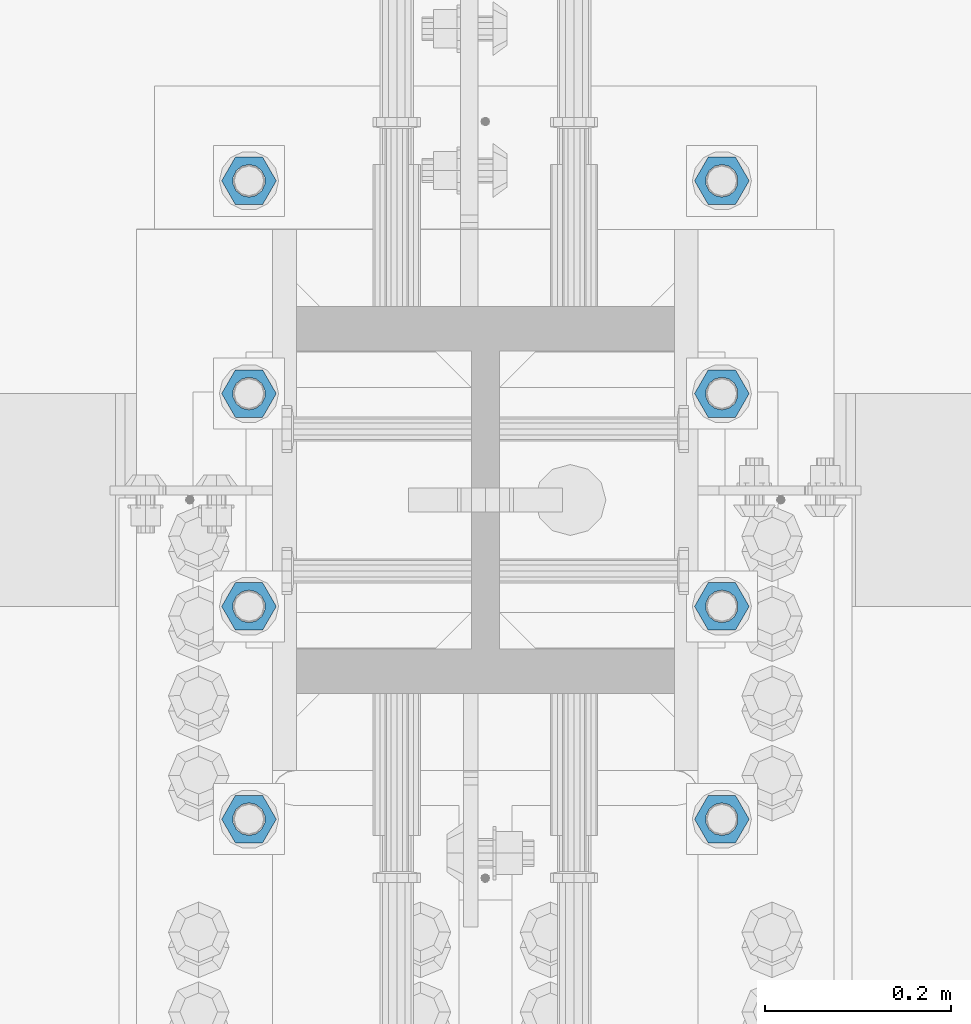
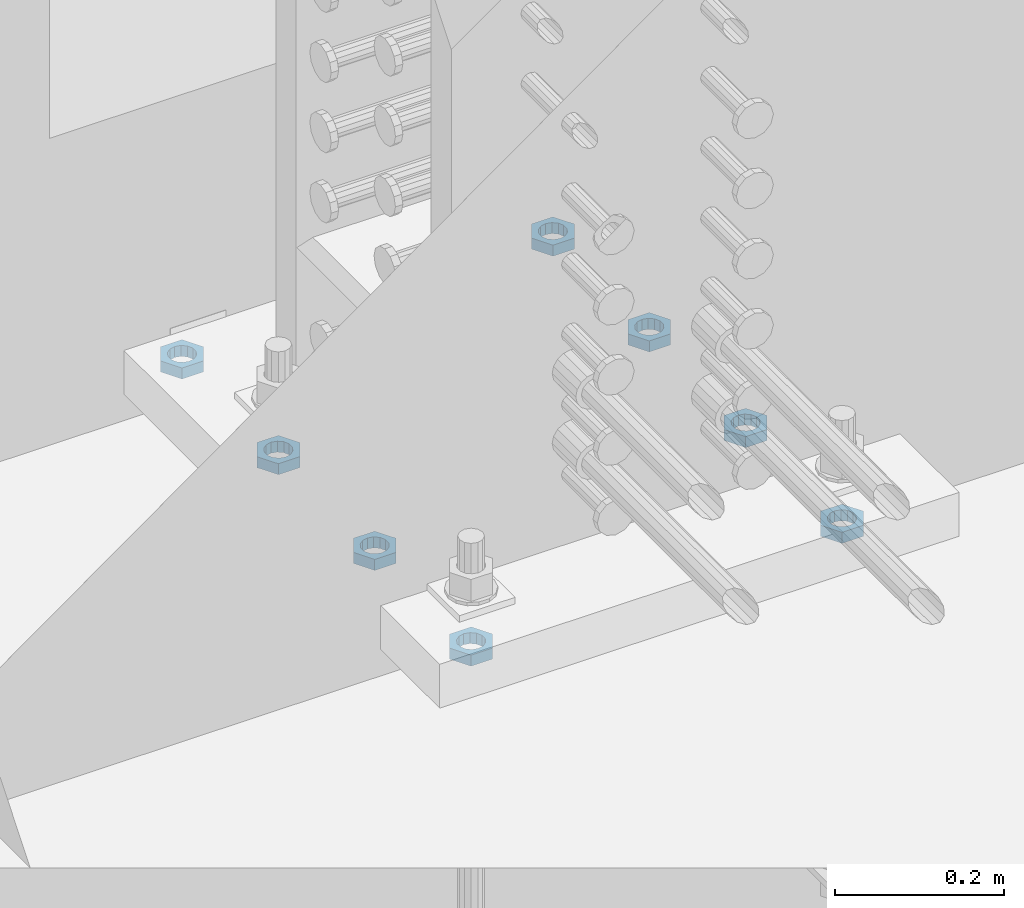
# One storey, part 1402 of 1763: 8 beams, 1 element without a shape of its own.
"""IFC2X3 building model written with IfcOpenShell, lengths in millimetres."""

import ifcopenshell
import ifcopenshell.guid

model = None  # the IFC model being written
_history = None  # IfcOwnerHistory: only IFC2X3 demands one
_inside = {}  # id of a spatial element -> (the spatial element, [elements in it])
_under = {}  # id of a project, library or spatial element -> (it, [spatial elements below it])
_declared = {}  # id of a project -> (the project, [libraries it declares])
_typed = {}  # id of a type object -> (the type object, [elements of that type])
_made_of = {}  # id of a material, layer set ... -> (it, [elements and type objects made of it])


def new_model(schema):
    """Start an empty IFC model of exactly this schema.

    Asked for "IFC4X3", IfcOpenShell would pick the latest addendum, in which some entities
    have other attributes; the version numbers below select the first issue.
    IFC2X3 requires an IfcOwnerHistory on every rooted entity: one is made here for all.
    """
    global model, _history
    if schema == "IFC4X3":
        model = ifcopenshell.file(schema_version=(4, 3, 0, 0))
    else:
        model = ifcopenshell.file(schema=schema)
    _inside.clear()
    _under.clear()
    _declared.clear()
    _typed.clear()
    _made_of.clear()
    _history = None
    if model.schema == "IFC2X3":
        org = make("IfcOrganization", Name="unknown")
        user = make(
            "IfcPersonAndOrganization",
            ThePerson=make("IfcPerson", FamilyName="unknown"),
            TheOrganization=org,
        )
        app = make(
            "IfcApplication",
            ApplicationDeveloper=org,
            Version="unknown",
            ApplicationFullName="unknown",
            ApplicationIdentifier="unknown",
        )
        _history = make(
            "IfcOwnerHistory",
            OwningUser=user,
            OwningApplication=app,
            ChangeAction="ADDED",
            CreationDate=0,
        )
    return model


def make(cls, **values):
    """One entity of the class cls with the attributes given. An attribute that is None is left unset."""
    return model.create_entity(
        cls, **{name: value for name, value in values.items() if value is not None}
    )


def rooted(cls, **values):
    """An entity with a GlobalId (a new one), such as an element, a storey or a relation."""
    return make(cls, GlobalId=ifcopenshell.guid.new(), OwnerHistory=_history, **values)


def si_unit(unit_type, name, prefix=None):
    """IfcSIUnit, for example si_unit("LENGTHUNIT", "METRE", prefix="MILLI")."""
    return make("IfcSIUnit", UnitType=unit_type, Prefix=prefix, Name=name)


def assignment(units):
    """IfcUnitAssignment: the units of a project."""
    return None if units is None else make("IfcUnitAssignment", Units=units)


def point(xyz):
    """IfcCartesianPoint."""
    return None if xyz is None else make("IfcCartesianPoint", Coordinates=xyz)


def direction(xyz):
    """IfcDirection."""
    return None if xyz is None else make("IfcDirection", DirectionRatios=xyz)


def frame(location, z_axis=None, x_axis=None):
    """IfcAxis2Placement3D, a coordinate frame: its origin and axes. An axis left out is left unset."""
    return make(
        "IfcAxis2Placement3D",
        Location=point(location),
        Axis=direction(z_axis),
        RefDirection=direction(x_axis),
    )


def origin_with_axes():
    """The frame at (0, 0, 0) with the z axis (0, 0, 1) and the x axis (1, 0, 0) written out."""
    return frame((0.0, 0.0, 0.0), z_axis=(0.0, 0.0, 1.0), x_axis=(1.0, 0.0, 0.0))


def place(relative_to, where):
    """IfcLocalPlacement: puts the frame where relative to a parent placement (None: the world)."""
    return make(
        "IfcLocalPlacement", PlacementRelTo=relative_to, RelativePlacement=where
    )


def context(
    kind, dimensions, precision=None, world=None, true_north=None, identifier=None
):
    """IfcGeometricRepresentationContext, for example the 3D "Model" context."""
    return make(
        "IfcGeometricRepresentationContext",
        ContextIdentifier=identifier,
        ContextType=kind,
        CoordinateSpaceDimension=dimensions,
        Precision=precision,
        WorldCoordinateSystem=world,
        TrueNorth=true_north,
    )


def subcontext(parent, identifier, kind, view, scale=None):
    """IfcGeometricRepresentationSubContext, for example "Body" below "Model"."""
    return make(
        "IfcGeometricRepresentationSubContext",
        ContextIdentifier=identifier,
        ContextType=kind,
        ParentContext=parent,
        TargetScale=scale,
        TargetView=view,
    )


def project(units=None, contexts=None):
    """IfcProject with its units and contexts."""
    return rooted(
        "IfcProject",
        Name="project",
        RepresentationContexts=contexts,
        UnitsInContext=assignment(units),
    )


def spatial(cls, under=None, at=None, **own):
    """A site, building, storey or space (cls), placed at a placement, below another one or the project."""
    s = rooted(cls, ObjectPlacement=at, **own)
    if under is not None:
        _under.setdefault(under.id(), (under, []))[1].append(s)
    return s


def faces_of(points, faces, orient=None, outer=None):
    """IfcFace entities. A face is a list of loops; a loop is a list of indices into points, from 0.

    orient and outer hold one flag for each loop. By default every Orientation is true, the
    first loop of a face is its IfcFaceOuterBound and the others are IfcFaceBound.
    """
    made = []
    for i, loops in enumerate(faces):
        bounds = []
        for j, loop in enumerate(loops):
            is_outer = j == 0 if outer is None else outer[i][j]
            bounds.append(
                make(
                    "IfcFaceOuterBound" if is_outer else "IfcFaceBound",
                    Bound=make("IfcPolyLoop", Polygon=[points[k] for k in loop]),
                    Orientation=True if orient is None else orient[i][j],
                )
            )
        made.append(make("IfcFace", Bounds=bounds))
    return made


def faceted_brep(points, faces, orient=None, outer=None, voids=None):
    """IfcFacetedBrep: a solid bounded by flat faces; with voids (closed shells), ...WithVoids."""
    shared = [point(p) for p in points]
    hull = make("IfcClosedShell", CfsFaces=faces_of(shared, faces, orient, outer))
    if voids is None:
        return make("IfcFacetedBrep", Outer=hull)
    return make(
        "IfcFacetedBrepWithVoids",
        Outer=hull,
        Voids=[
            make(cls, CfsFaces=faces_of(shared, fs, o, b)) for cls, fs, o, b in voids
        ],
    )


def shape(context_of_items, identifier, shape_type, items):
    """IfcShapeRepresentation: the items that make up one representation, for example the "Body"."""
    return make(
        "IfcShapeRepresentation",
        ContextOfItems=context_of_items,
        RepresentationIdentifier=identifier,
        RepresentationType=shape_type,
        Items=items,
    )


def material(Name=None, Category=None):
    """IfcMaterial."""
    return make("IfcMaterial", Name=Name, Category=Category)


def made_of(thing, what):
    """Note that an element or type object is made of a material, layer set ...; save() writes the relation."""
    if what is not None:
        _made_of.setdefault(what.id(), (what, []))[1].append(thing)
    return thing


def type_object(cls, material=None, **own):
    """A type object (cls), such as IfcWallType, which elements share."""
    return made_of(rooted(cls, **own), material)


def element(
    cls,
    number,
    at=None,
    inside=None,
    cuts=None,
    type_object=None,
    material=None,
    context=None,
    identifier="Body",
    shape_type=None,
    held_by="IfcProductDefinitionShape",
    body=None,
    shapes=None,
    **own,
):
    """One element of the class cls, such as IfcWall. Its Tag is "e" and its number.

    at: its placement. inside: the storey or other place that contains it. cuts: it is an
    opening in that element (IfcRelVoidsElement). A single representation is given by context,
    identifier, shape_type and body (its items); several are given by shapes. held_by: the class
    of the entity that holds the representations. save() writes the other relations.
    """
    e = rooted(cls, Tag="e%d" % number, ObjectPlacement=at, **own)
    if body is not None:
        shapes = [shape(context, identifier, shape_type, body)]
    if shapes is not None:
        e.Representation = make(held_by, Representations=shapes)
    if inside is not None:
        _inside.setdefault(inside.id(), (inside, []))[1].append(e)
    if cuts is not None:
        rooted(
            "IfcRelVoidsElement", RelatingBuildingElement=cuts, RelatedOpeningElement=e
        )
    if type_object is not None:
        _typed.setdefault(type_object.id(), (type_object, []))[1].append(e)
    return made_of(e, material)


def aggregate(whole, parts):
    """IfcRelAggregates: a whole, such as a stair, and the parts it consists of."""
    return rooted("IfcRelAggregates", RelatingObject=whole, RelatedObjects=parts)


def save(model, path):
    """Write the relations noted so far, then the file.

    IfcRelAggregates (storeys below a building ...), IfcRelContainedInSpatialStructure (elements
    in a storey), IfcRelDefinesByType, IfcRelAssociatesMaterial and IfcRelDeclares: one each for
    every whole, place, type object, material and project.
    """
    for whole, parts in _under.values():
        aggregate(whole, parts)
    for where, things in _inside.values():
        rooted(
            "IfcRelContainedInSpatialStructure",
            RelatedElements=things,
            RelatingStructure=where,
        )
    for kind, things in _typed.values():
        rooted("IfcRelDefinesByType", RelatedObjects=things, RelatingType=kind)
    for what, things in _made_of.values():
        rooted("IfcRelAssociatesMaterial", RelatedObjects=things, RelatingMaterial=what)
    for by, libraries in _declared.values():
        rooted("IfcRelDeclares", RelatingContext=by, RelatedDefinitions=libraries)
    model.write(path)


model = new_model("IFC2X3")

# Units and contexts
model_context = context("Model", 3, precision=1e-05, world=origin_with_axes())
body_context = subcontext(model_context, "Body", "Model", "MODEL_VIEW")
ifc_project = project(units=[si_unit("LENGTHUNIT", "METRE", prefix="MILLI"), si_unit("AREAUNIT", "SQUARE_METRE"), si_unit("VOLUMEUNIT", "CUBIC_METRE"), si_unit("MASSUNIT", "GRAM", prefix="KILO"), si_unit("TIMEUNIT", "SECOND"), si_unit("PLANEANGLEUNIT", "RADIAN"), si_unit("SOLIDANGLEUNIT", "STERADIAN"), si_unit("THERMODYNAMICTEMPERATUREUNIT", "DEGREE_CELSIUS"), si_unit("LUMINOUSINTENSITYUNIT", "LUMEN")], contexts=[model_context])

# Site, building, storey
site_placement = place(None, origin_with_axes())
site = spatial("IfcSite", under=ifc_project, at=site_placement, CompositionType="ELEMENT")
building_placement = place(site_placement, origin_with_axes())
building = spatial("IfcBuilding", under=site, at=building_placement, Name="Undefined", CompositionType="ELEMENT")
storey_placement = place(building_placement, origin_with_axes())
storey = spatial("IfcBuildingStorey", under=building, at=storey_placement, Name="Undefined", CompositionType="ELEMENT", Elevation=0.0)

# Assembly, beams
assembly_placement = place(storey_placement, origin_with_axes())
assembly = element("IfcElementAssembly", 1, at=assembly_placement, inside=storey, Name="TEMPLATE", AssemblyPlace="NOTDEFINED", PredefinedType="RIGID_FRAME")
ifc_material = material(Name="STEEL/A563")
beam_type = type_object("IfcBeamType", Name="1-1/4_DIA. HALF_NUT", PredefinedType="NOTDEFINED")
beam_1_placement = place(assembly_placement, frame((-23773.8372736984, 14033.4999999999, 3848.1), z_axis=(0.0, 1.0, 0.0), x_axis=(0.0, 0.0, -1.0)))
beam_1 = element("IfcBeam", 2, at=beam_1_placement, type_object=beam_type, material=ifc_material, Name="NUT", ObjectType="1-1/4_DIA. HALF_NUT", context=body_context, shape_type="Brep", body=[
    faceted_brep([(0.0, -29.3700008392334, 0.0), (0.0, -14.6800003051758, -25.4300003051758), (15.875, -14.6800003051758, -25.4300003051758), (15.875, -29.3700008392334, 0.0), (0.0, 14.6800003051758, -25.4300003051758), (15.875, 14.6800003051758, -25.4300003051758), (0.0, 29.3700008392334, 0.0), (15.875, 29.3700008392334, 0.0), (0.0, 14.6800003051758, 25.4300003051758), (15.875, 14.6800003051758, 25.4300003051758), (0.0, -14.6800003051758, 25.4300003051758), (15.875, -14.6800003051758, 25.4300003051758), (0.0, 0.0, 17.4599990844727), (0.0, 7.57560968776022, 15.730915608714), (15.875, 7.57560968776022, 15.730915608714), (15.875, 0.0, 17.4599990844727), (0.0, 13.6507769681037, 10.8861313696252), (15.875, 13.6507769681037, 10.8861313696252), (0.0, 17.0222404541215, 3.88521530314756), (15.875, 17.0222404541215, 3.88521530314756), (0.0, 17.0222404541215, -3.88521530314756), (15.875, 17.0222404541215, -3.88521530314756), (0.0, 13.6507769681037, -10.8861313696252), (15.875, 13.6507769681037, -10.8861313696252), (0.0, 7.57560968776022, -15.730915608714), (15.875, 7.57560968776022, -15.730915608714), (0.0, 0.0, -17.4599990844727), (15.875, 0.0, -17.4599990844727), (0.0, -7.57560968776022, -15.730915608714), (15.875, -7.57560968776022, -15.730915608714), (0.0, -13.6507769681037, -10.8861313696252), (15.875, -13.6507769681037, -10.8861313696252), (0.0, -17.0222404541215, -3.88521530314756), (15.875, -17.0222404541215, -3.88521530314756), (0.0, -17.0222404541215, 3.88521530314756), (15.875, -17.0222404541215, 3.88521530314756), (0.0, -13.6507769681037, 10.8861313696252), (15.875, -13.6507769681037, 10.8861313696252), (0.0, -7.57560968776022, 15.730915608714), (15.875, -7.57560968776022, 15.730915608714)], [[[0, 1, 2, 3]], [[1, 4, 5, 2]], [[4, 6, 7, 5]], [[6, 8, 9, 7]], [[8, 10, 11, 9]], [[10, 0, 3, 11]], [[12, 13, 14, 15]], [[13, 16, 17, 14]], [[16, 18, 19, 17]], [[18, 20, 21, 19]], [[20, 22, 23, 21]], [[22, 24, 25, 23]], [[24, 26, 27, 25]], [[26, 28, 29, 27]], [[28, 30, 31, 29]], [[30, 32, 33, 31]], [[32, 34, 35, 33]], [[34, 36, 37, 35]], [[36, 38, 39, 37]], [[38, 12, 15, 39]], [[5, 7, 9, 11, 3, 2], [17, 19, 21, 23, 25, 27, 29, 31, 33, 35, 37, 39, 15, 14]], [[10, 8, 6, 4, 1, 0], [38, 36, 34, 32, 30, 28, 26, 24, 22, 20, 18, 16, 13, 12]]]),
])
beam_2_placement = place(assembly_placement, frame((-24281.8372736984, 14033.4999999999, 3848.1), z_axis=(0.0, -1.0, 0.0), x_axis=(0.0, 0.0, -1.0)))
beam_2 = element("IfcBeam", 3, at=beam_2_placement, type_object=beam_type, material=ifc_material, Name="NUT", ObjectType="1-1/4_DIA. HALF_NUT", context=body_context, shape_type="Brep", body=[
    faceted_brep([(0.0, -29.3700008392334, 0.0), (0.0, -14.6800003051758, -25.4300003051758), (15.875, -14.6800003051758, -25.4300003051758), (15.875, -29.3700008392334, 0.0), (0.0, 14.6800003051758, -25.4300003051758), (15.875, 14.6800003051758, -25.4300003051758), (0.0, 29.3700008392334, 0.0), (15.875, 29.3700008392334, 0.0), (0.0, 14.6800003051758, 25.4300003051758), (15.875, 14.6800003051758, 25.4300003051758), (0.0, -14.6800003051758, 25.4300003051758), (15.875, -14.6800003051758, 25.4300003051758), (0.0, 0.0, 17.4599990844727), (0.0, 7.57560968776022, 15.730915608714), (15.875, 7.57560968776022, 15.730915608714), (15.875, 0.0, 17.4599990844727), (0.0, 13.6507769681037, 10.8861313696252), (15.875, 13.6507769681037, 10.8861313696252), (0.0, 17.0222404541215, 3.88521530314756), (15.875, 17.0222404541215, 3.88521530314756), (0.0, 17.0222404541215, -3.88521530314756), (15.875, 17.0222404541215, -3.88521530314756), (0.0, 13.6507769681037, -10.8861313696252), (15.875, 13.6507769681037, -10.8861313696252), (0.0, 7.57560968776022, -15.730915608714), (15.875, 7.57560968776022, -15.730915608714), (0.0, 0.0, -17.4599990844727), (15.875, 0.0, -17.4599990844727), (0.0, -7.57560968776022, -15.730915608714), (15.875, -7.57560968776022, -15.730915608714), (0.0, -13.6507769681037, -10.8861313696252), (15.875, -13.6507769681037, -10.8861313696252), (0.0, -17.0222404541215, -3.88521530314756), (15.875, -17.0222404541215, -3.88521530314756), (0.0, -17.0222404541215, 3.88521530314756), (15.875, -17.0222404541215, 3.88521530314756), (0.0, -13.6507769681037, 10.8861313696252), (15.875, -13.6507769681037, 10.8861313696252), (0.0, -7.57560968776022, 15.730915608714), (15.875, -7.57560968776022, 15.730915608714)], [[[0, 1, 2, 3]], [[1, 4, 5, 2]], [[4, 6, 7, 5]], [[6, 8, 9, 7]], [[8, 10, 11, 9]], [[10, 0, 3, 11]], [[12, 13, 14, 15]], [[13, 16, 17, 14]], [[16, 18, 19, 17]], [[18, 20, 21, 19]], [[20, 22, 23, 21]], [[22, 24, 25, 23]], [[24, 26, 27, 25]], [[26, 28, 29, 27]], [[28, 30, 31, 29]], [[30, 32, 33, 31]], [[32, 34, 35, 33]], [[34, 36, 37, 35]], [[36, 38, 39, 37]], [[38, 12, 15, 39]], [[5, 7, 9, 11, 3, 2], [17, 19, 21, 23, 25, 27, 29, 31, 33, 35, 37, 39, 15, 14]], [[10, 8, 6, 4, 1, 0], [38, 36, 34, 32, 30, 28, 26, 24, 22, 20, 18, 16, 13, 12]]]),
])
beam_3_placement = place(assembly_placement, frame((-23773.8372736984, 13804.8999999999, 3848.1), z_axis=(0.0, 1.0, 0.0), x_axis=(0.0, 0.0, -1.0)))
beam_3 = element("IfcBeam", 4, at=beam_3_placement, type_object=beam_type, material=ifc_material, Name="NUT", ObjectType="1-1/4_DIA. HALF_NUT", context=body_context, shape_type="Brep", body=[
    faceted_brep([(0.0, -29.3700008392334, 0.0), (0.0, -14.6800003051758, -25.4300003051758), (15.875, -14.6800003051758, -25.4300003051758), (15.875, -29.3700008392334, 0.0), (0.0, 14.6800003051758, -25.4300003051758), (15.875, 14.6800003051758, -25.4300003051758), (0.0, 29.3700008392334, 0.0), (15.875, 29.3700008392334, 0.0), (0.0, 14.6800003051758, 25.4300003051758), (15.875, 14.6800003051758, 25.4300003051758), (0.0, -14.6800003051758, 25.4300003051758), (15.875, -14.6800003051758, 25.4300003051758), (0.0, 0.0, 17.4599990844727), (0.0, 7.57560968776022, 15.730915608714), (15.875, 7.57560968776022, 15.730915608714), (15.875, 0.0, 17.4599990844727), (0.0, 13.6507769681037, 10.8861313696252), (15.875, 13.6507769681037, 10.8861313696252), (0.0, 17.0222404541215, 3.88521530314756), (15.875, 17.0222404541215, 3.88521530314756), (0.0, 17.0222404541215, -3.88521530314756), (15.875, 17.0222404541215, -3.88521530314756), (0.0, 13.6507769681037, -10.8861313696252), (15.875, 13.6507769681037, -10.8861313696252), (0.0, 7.57560968776022, -15.730915608714), (15.875, 7.57560968776022, -15.730915608714), (0.0, 0.0, -17.4599990844727), (15.875, 0.0, -17.4599990844727), (0.0, -7.57560968776022, -15.730915608714), (15.875, -7.57560968776022, -15.730915608714), (0.0, -13.6507769681037, -10.8861313696252), (15.875, -13.6507769681037, -10.8861313696252), (0.0, -17.0222404541215, -3.88521530314756), (15.875, -17.0222404541215, -3.88521530314756), (0.0, -17.0222404541215, 3.88521530314756), (15.875, -17.0222404541215, 3.88521530314756), (0.0, -13.6507769681037, 10.8861313696252), (15.875, -13.6507769681037, 10.8861313696252), (0.0, -7.57560968776022, 15.730915608714), (15.875, -7.57560968776022, 15.730915608714)], [[[0, 1, 2, 3]], [[1, 4, 5, 2]], [[4, 6, 7, 5]], [[6, 8, 9, 7]], [[8, 10, 11, 9]], [[10, 0, 3, 11]], [[12, 13, 14, 15]], [[13, 16, 17, 14]], [[16, 18, 19, 17]], [[18, 20, 21, 19]], [[20, 22, 23, 21]], [[22, 24, 25, 23]], [[24, 26, 27, 25]], [[26, 28, 29, 27]], [[28, 30, 31, 29]], [[30, 32, 33, 31]], [[32, 34, 35, 33]], [[34, 36, 37, 35]], [[36, 38, 39, 37]], [[38, 12, 15, 39]], [[5, 7, 9, 11, 3, 2], [17, 19, 21, 23, 25, 27, 29, 31, 33, 35, 37, 39, 15, 14]], [[10, 8, 6, 4, 1, 0], [38, 36, 34, 32, 30, 28, 26, 24, 22, 20, 18, 16, 13, 12]]]),
])
beam_4_placement = place(assembly_placement, frame((-24281.8372736984, 13804.8999999999, 3848.1), z_axis=(0.0, -1.0, 0.0), x_axis=(0.0, 0.0, -1.0)))
beam_4 = element("IfcBeam", 5, at=beam_4_placement, type_object=beam_type, material=ifc_material, Name="NUT", ObjectType="1-1/4_DIA. HALF_NUT", context=body_context, shape_type="Brep", body=[
    faceted_brep([(0.0, -29.3700008392334, 0.0), (0.0, -14.6800003051758, -25.4300003051758), (15.875, -14.6800003051758, -25.4300003051758), (15.875, -29.3700008392334, 0.0), (0.0, 14.6800003051758, -25.4300003051758), (15.875, 14.6800003051758, -25.4300003051758), (0.0, 29.3700008392334, 0.0), (15.875, 29.3700008392334, 0.0), (0.0, 14.6800003051758, 25.4300003051758), (15.875, 14.6800003051758, 25.4300003051758), (0.0, -14.6800003051758, 25.4300003051758), (15.875, -14.6800003051758, 25.4300003051758), (0.0, 0.0, 17.4599990844727), (0.0, 7.57560968776022, 15.730915608714), (15.875, 7.57560968776022, 15.730915608714), (15.875, 0.0, 17.4599990844727), (0.0, 13.6507769681037, 10.8861313696252), (15.875, 13.6507769681037, 10.8861313696252), (0.0, 17.0222404541215, 3.88521530314756), (15.875, 17.0222404541215, 3.88521530314756), (0.0, 17.0222404541215, -3.88521530314756), (15.875, 17.0222404541215, -3.88521530314756), (0.0, 13.6507769681037, -10.8861313696252), (15.875, 13.6507769681037, -10.8861313696252), (0.0, 7.57560968776022, -15.730915608714), (15.875, 7.57560968776022, -15.730915608714), (0.0, 0.0, -17.4599990844727), (15.875, 0.0, -17.4599990844727), (0.0, -7.57560968776022, -15.730915608714), (15.875, -7.57560968776022, -15.730915608714), (0.0, -13.6507769681037, -10.8861313696252), (15.875, -13.6507769681037, -10.8861313696252), (0.0, -17.0222404541215, -3.88521530314756), (15.875, -17.0222404541215, -3.88521530314756), (0.0, -17.0222404541215, 3.88521530314756), (15.875, -17.0222404541215, 3.88521530314756), (0.0, -13.6507769681037, 10.8861313696252), (15.875, -13.6507769681037, 10.8861313696252), (0.0, -7.57560968776022, 15.730915608714), (15.875, -7.57560968776022, 15.730915608714)], [[[0, 1, 2, 3]], [[1, 4, 5, 2]], [[4, 6, 7, 5]], [[6, 8, 9, 7]], [[8, 10, 11, 9]], [[10, 0, 3, 11]], [[12, 13, 14, 15]], [[13, 16, 17, 14]], [[16, 18, 19, 17]], [[18, 20, 21, 19]], [[20, 22, 23, 21]], [[22, 24, 25, 23]], [[24, 26, 27, 25]], [[26, 28, 29, 27]], [[28, 30, 31, 29]], [[30, 32, 33, 31]], [[32, 34, 35, 33]], [[34, 36, 37, 35]], [[36, 38, 39, 37]], [[38, 12, 15, 39]], [[5, 7, 9, 11, 3, 2], [17, 19, 21, 23, 25, 27, 29, 31, 33, 35, 37, 39, 15, 14]], [[10, 8, 6, 4, 1, 0], [38, 36, 34, 32, 30, 28, 26, 24, 22, 20, 18, 16, 13, 12]]]),
])
beam_5_placement = place(assembly_placement, frame((-23773.8372736984, 13576.2999999999, 3848.1), z_axis=(0.0, 1.0, 0.0), x_axis=(0.0, 0.0, -1.0)))
beam_5 = element("IfcBeam", 6, at=beam_5_placement, type_object=beam_type, material=ifc_material, Name="NUT", ObjectType="1-1/4_DIA. HALF_NUT", context=body_context, shape_type="Brep", body=[
    faceted_brep([(0.0, -29.3700008392334, 0.0), (0.0, -14.6800003051758, -25.4300003051758), (15.875, -14.6800003051758, -25.4300003051758), (15.875, -29.3700008392334, 0.0), (0.0, 14.6800003051758, -25.4300003051758), (15.875, 14.6800003051758, -25.4300003051758), (0.0, 29.3700008392334, 0.0), (15.875, 29.3700008392334, 0.0), (0.0, 14.6800003051758, 25.4300003051758), (15.875, 14.6800003051758, 25.4300003051758), (0.0, -14.6800003051758, 25.4300003051758), (15.875, -14.6800003051758, 25.4300003051758), (0.0, 0.0, 17.4599990844727), (0.0, 7.57560968776022, 15.730915608714), (15.875, 7.57560968776022, 15.730915608714), (15.875, 0.0, 17.4599990844727), (0.0, 13.6507769681037, 10.8861313696252), (15.875, 13.6507769681037, 10.8861313696252), (0.0, 17.0222404541215, 3.88521530314756), (15.875, 17.0222404541215, 3.88521530314756), (0.0, 17.0222404541215, -3.88521530314756), (15.875, 17.0222404541215, -3.88521530314756), (0.0, 13.6507769681037, -10.8861313696252), (15.875, 13.6507769681037, -10.8861313696252), (0.0, 7.57560968776022, -15.730915608714), (15.875, 7.57560968776022, -15.730915608714), (0.0, 0.0, -17.4599990844727), (15.875, 0.0, -17.4599990844727), (0.0, -7.57560968776022, -15.730915608714), (15.875, -7.57560968776022, -15.730915608714), (0.0, -13.6507769681037, -10.8861313696252), (15.875, -13.6507769681037, -10.8861313696252), (0.0, -17.0222404541215, -3.88521530314756), (15.875, -17.0222404541215, -3.88521530314756), (0.0, -17.0222404541215, 3.88521530314756), (15.875, -17.0222404541215, 3.88521530314756), (0.0, -13.6507769681037, 10.8861313696252), (15.875, -13.6507769681037, 10.8861313696252), (0.0, -7.57560968776022, 15.730915608714), (15.875, -7.57560968776022, 15.730915608714)], [[[0, 1, 2, 3]], [[1, 4, 5, 2]], [[4, 6, 7, 5]], [[6, 8, 9, 7]], [[8, 10, 11, 9]], [[10, 0, 3, 11]], [[12, 13, 14, 15]], [[13, 16, 17, 14]], [[16, 18, 19, 17]], [[18, 20, 21, 19]], [[20, 22, 23, 21]], [[22, 24, 25, 23]], [[24, 26, 27, 25]], [[26, 28, 29, 27]], [[28, 30, 31, 29]], [[30, 32, 33, 31]], [[32, 34, 35, 33]], [[34, 36, 37, 35]], [[36, 38, 39, 37]], [[38, 12, 15, 39]], [[5, 7, 9, 11, 3, 2], [17, 19, 21, 23, 25, 27, 29, 31, 33, 35, 37, 39, 15, 14]], [[10, 8, 6, 4, 1, 0], [38, 36, 34, 32, 30, 28, 26, 24, 22, 20, 18, 16, 13, 12]]]),
])
beam_6_placement = place(assembly_placement, frame((-24281.8372736984, 13576.2999999999, 3848.1), z_axis=(0.0, -1.0, 0.0), x_axis=(0.0, 0.0, -1.0)))
beam_6 = element("IfcBeam", 7, at=beam_6_placement, type_object=beam_type, material=ifc_material, Name="NUT", ObjectType="1-1/4_DIA. HALF_NUT", context=body_context, shape_type="Brep", body=[
    faceted_brep([(0.0, -29.3700008392334, 0.0), (0.0, -14.6800003051758, -25.4300003051758), (15.875, -14.6800003051758, -25.4300003051758), (15.875, -29.3700008392334, 0.0), (0.0, 14.6800003051758, -25.4300003051758), (15.875, 14.6800003051758, -25.4300003051758), (0.0, 29.3700008392334, 0.0), (15.875, 29.3700008392334, 0.0), (0.0, 14.6800003051758, 25.4300003051758), (15.875, 14.6800003051758, 25.4300003051758), (0.0, -14.6800003051758, 25.4300003051758), (15.875, -14.6800003051758, 25.4300003051758), (0.0, 0.0, 17.4599990844727), (0.0, 7.57560968776022, 15.730915608714), (15.875, 7.57560968776022, 15.730915608714), (15.875, 0.0, 17.4599990844727), (0.0, 13.6507769681037, 10.8861313696252), (15.875, 13.6507769681037, 10.8861313696252), (0.0, 17.0222404541215, 3.88521530314756), (15.875, 17.0222404541215, 3.88521530314756), (0.0, 17.0222404541215, -3.88521530314756), (15.875, 17.0222404541215, -3.88521530314756), (0.0, 13.6507769681037, -10.8861313696252), (15.875, 13.6507769681037, -10.8861313696252), (0.0, 7.57560968776022, -15.730915608714), (15.875, 7.57560968776022, -15.730915608714), (0.0, 0.0, -17.4599990844727), (15.875, 0.0, -17.4599990844727), (0.0, -7.57560968776022, -15.730915608714), (15.875, -7.57560968776022, -15.730915608714), (0.0, -13.6507769681037, -10.8861313696252), (15.875, -13.6507769681037, -10.8861313696252), (0.0, -17.0222404541215, -3.88521530314756), (15.875, -17.0222404541215, -3.88521530314756), (0.0, -17.0222404541215, 3.88521530314756), (15.875, -17.0222404541215, 3.88521530314756), (0.0, -13.6507769681037, 10.8861313696252), (15.875, -13.6507769681037, 10.8861313696252), (0.0, -7.57560968776022, 15.730915608714), (15.875, -7.57560968776022, 15.730915608714)], [[[0, 1, 2, 3]], [[1, 4, 5, 2]], [[4, 6, 7, 5]], [[6, 8, 9, 7]], [[8, 10, 11, 9]], [[10, 0, 3, 11]], [[12, 13, 14, 15]], [[13, 16, 17, 14]], [[16, 18, 19, 17]], [[18, 20, 21, 19]], [[20, 22, 23, 21]], [[22, 24, 25, 23]], [[24, 26, 27, 25]], [[26, 28, 29, 27]], [[28, 30, 31, 29]], [[30, 32, 33, 31]], [[32, 34, 35, 33]], [[34, 36, 37, 35]], [[36, 38, 39, 37]], [[38, 12, 15, 39]], [[5, 7, 9, 11, 3, 2], [17, 19, 21, 23, 25, 27, 29, 31, 33, 35, 37, 39, 15, 14]], [[10, 8, 6, 4, 1, 0], [38, 36, 34, 32, 30, 28, 26, 24, 22, 20, 18, 16, 13, 12]]]),
])
beam_7_placement = place(assembly_placement, frame((-24281.8372736984, 13347.6999999999, 3848.1), z_axis=(0.0, -1.0, 0.0), x_axis=(0.0, 0.0, -1.0)))
beam_7 = element("IfcBeam", 8, at=beam_7_placement, type_object=beam_type, material=ifc_material, Name="NUT", ObjectType="1-1/4_DIA. HALF_NUT", context=body_context, shape_type="Brep", body=[
    faceted_brep([(0.0, -29.3700008392334, 0.0), (0.0, -14.6800003051758, -25.4300003051758), (15.875, -14.6800003051758, -25.4300003051758), (15.875, -29.3700008392334, 0.0), (0.0, 14.6800003051758, -25.4300003051758), (15.875, 14.6800003051758, -25.4300003051758), (0.0, 29.3700008392334, 0.0), (15.875, 29.3700008392334, 0.0), (0.0, 14.6800003051758, 25.4300003051758), (15.875, 14.6800003051758, 25.4300003051758), (0.0, -14.6800003051758, 25.4300003051758), (15.875, -14.6800003051758, 25.4300003051758), (0.0, 0.0, 17.4599990844727), (0.0, 7.57560968776022, 15.730915608714), (15.875, 7.57560968776022, 15.730915608714), (15.875, 0.0, 17.4599990844727), (0.0, 13.6507769681037, 10.8861313696252), (15.875, 13.6507769681037, 10.8861313696252), (0.0, 17.0222404541215, 3.88521530314756), (15.875, 17.0222404541215, 3.88521530314756), (0.0, 17.0222404541215, -3.88521530314756), (15.875, 17.0222404541215, -3.88521530314756), (0.0, 13.6507769681037, -10.8861313696252), (15.875, 13.6507769681037, -10.8861313696252), (0.0, 7.57560968776022, -15.730915608714), (15.875, 7.57560968776022, -15.730915608714), (0.0, 0.0, -17.4599990844727), (15.875, 0.0, -17.4599990844727), (0.0, -7.57560968776022, -15.730915608714), (15.875, -7.57560968776022, -15.730915608714), (0.0, -13.6507769681037, -10.8861313696252), (15.875, -13.6507769681037, -10.8861313696252), (0.0, -17.0222404541215, -3.88521530314756), (15.875, -17.0222404541215, -3.88521530314756), (0.0, -17.0222404541215, 3.88521530314756), (15.875, -17.0222404541215, 3.88521530314756), (0.0, -13.6507769681037, 10.8861313696252), (15.875, -13.6507769681037, 10.8861313696252), (0.0, -7.57560968776022, 15.730915608714), (15.875, -7.57560968776022, 15.730915608714)], [[[0, 1, 2, 3]], [[1, 4, 5, 2]], [[4, 6, 7, 5]], [[6, 8, 9, 7]], [[8, 10, 11, 9]], [[10, 0, 3, 11]], [[12, 13, 14, 15]], [[13, 16, 17, 14]], [[16, 18, 19, 17]], [[18, 20, 21, 19]], [[20, 22, 23, 21]], [[22, 24, 25, 23]], [[24, 26, 27, 25]], [[26, 28, 29, 27]], [[28, 30, 31, 29]], [[30, 32, 33, 31]], [[32, 34, 35, 33]], [[34, 36, 37, 35]], [[36, 38, 39, 37]], [[38, 12, 15, 39]], [[5, 7, 9, 11, 3, 2], [17, 19, 21, 23, 25, 27, 29, 31, 33, 35, 37, 39, 15, 14]], [[10, 8, 6, 4, 1, 0], [38, 36, 34, 32, 30, 28, 26, 24, 22, 20, 18, 16, 13, 12]]]),
])
beam_8_placement = place(assembly_placement, frame((-23773.8372736984, 13347.6999999999, 3848.1), z_axis=(0.0, 1.0, 0.0), x_axis=(0.0, 0.0, -1.0)))
beam_8 = element("IfcBeam", 9, at=beam_8_placement, type_object=beam_type, material=ifc_material, Name="NUT", ObjectType="1-1/4_DIA. HALF_NUT", context=body_context, shape_type="Brep", body=[
    faceted_brep([(0.0, -29.3700008392334, 0.0), (0.0, -14.6800003051758, -25.4300003051758), (15.875, -14.6800003051758, -25.4300003051758), (15.875, -29.3700008392334, 0.0), (0.0, 14.6800003051758, -25.4300003051758), (15.875, 14.6800003051758, -25.4300003051758), (0.0, 29.3700008392334, 0.0), (15.875, 29.3700008392334, 0.0), (0.0, 14.6800003051758, 25.4300003051758), (15.875, 14.6800003051758, 25.4300003051758), (0.0, -14.6800003051758, 25.4300003051758), (15.875, -14.6800003051758, 25.4300003051758), (0.0, 0.0, 17.4599990844727), (0.0, 7.57560968776022, 15.730915608714), (15.875, 7.57560968776022, 15.730915608714), (15.875, 0.0, 17.4599990844727), (0.0, 13.6507769681037, 10.8861313696252), (15.875, 13.6507769681037, 10.8861313696252), (0.0, 17.0222404541215, 3.88521530314756), (15.875, 17.0222404541215, 3.88521530314756), (0.0, 17.0222404541215, -3.88521530314756), (15.875, 17.0222404541215, -3.88521530314756), (0.0, 13.6507769681037, -10.8861313696252), (15.875, 13.6507769681037, -10.8861313696252), (0.0, 7.57560968776022, -15.730915608714), (15.875, 7.57560968776022, -15.730915608714), (0.0, 0.0, -17.4599990844727), (15.875, 0.0, -17.4599990844727), (0.0, -7.57560968776022, -15.730915608714), (15.875, -7.57560968776022, -15.730915608714), (0.0, -13.6507769681037, -10.8861313696252), (15.875, -13.6507769681037, -10.8861313696252), (0.0, -17.0222404541215, -3.88521530314756), (15.875, -17.0222404541215, -3.88521530314756), (0.0, -17.0222404541215, 3.88521530314756), (15.875, -17.0222404541215, 3.88521530314756), (0.0, -13.6507769681037, 10.8861313696252), (15.875, -13.6507769681037, 10.8861313696252), (0.0, -7.57560968776022, 15.730915608714), (15.875, -7.57560968776022, 15.730915608714)], [[[0, 1, 2, 3]], [[1, 4, 5, 2]], [[4, 6, 7, 5]], [[6, 8, 9, 7]], [[8, 10, 11, 9]], [[10, 0, 3, 11]], [[12, 13, 14, 15]], [[13, 16, 17, 14]], [[16, 18, 19, 17]], [[18, 20, 21, 19]], [[20, 22, 23, 21]], [[22, 24, 25, 23]], [[24, 26, 27, 25]], [[26, 28, 29, 27]], [[28, 30, 31, 29]], [[30, 32, 33, 31]], [[32, 34, 35, 33]], [[34, 36, 37, 35]], [[36, 38, 39, 37]], [[38, 12, 15, 39]], [[5, 7, 9, 11, 3, 2], [17, 19, 21, 23, 25, 27, 29, 31, 33, 35, 37, 39, 15, 14]], [[10, 8, 6, 4, 1, 0], [38, 36, 34, 32, 30, 28, 26, 24, 22, 20, 18, 16, 13, 12]]]),
])
aggregate(assembly, [beam_1, beam_2, beam_3, beam_4, beam_5, beam_6, beam_7, beam_8])

save(model, "model.ifc")
